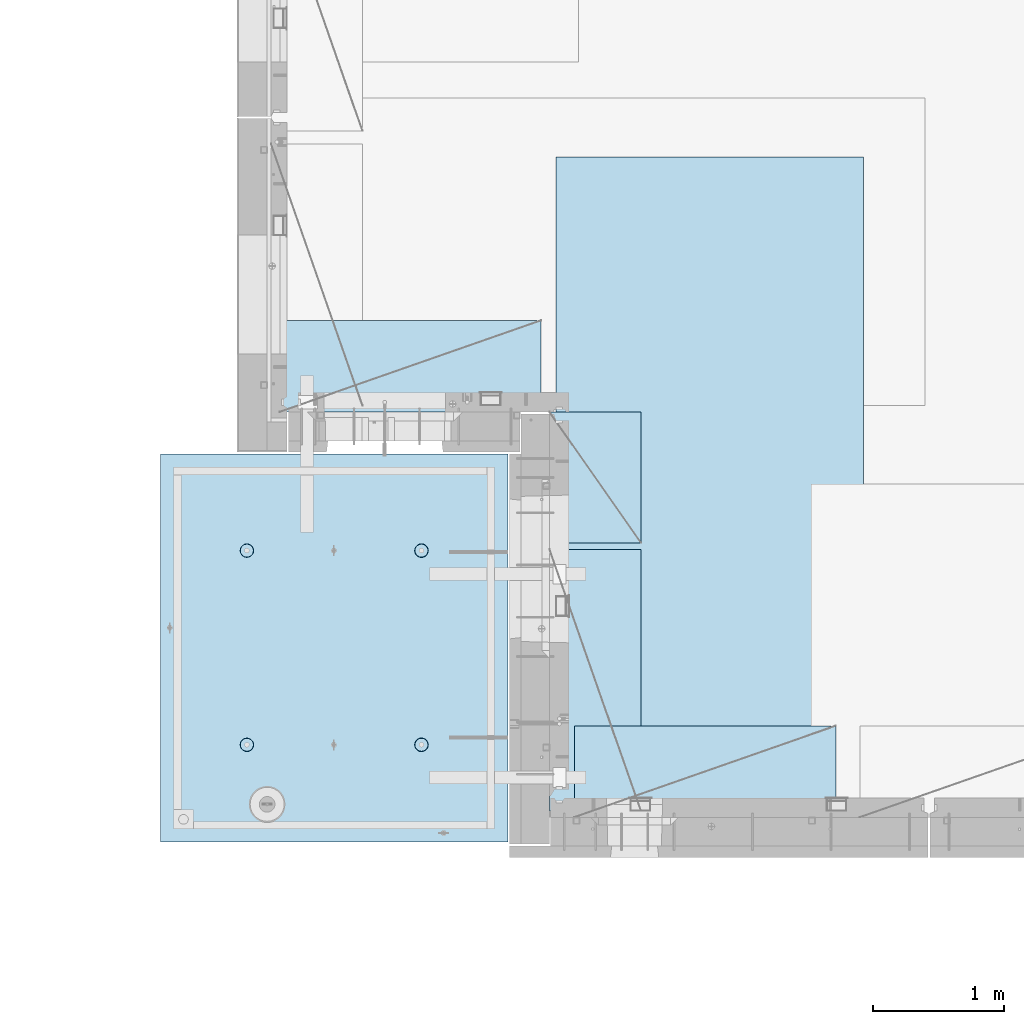
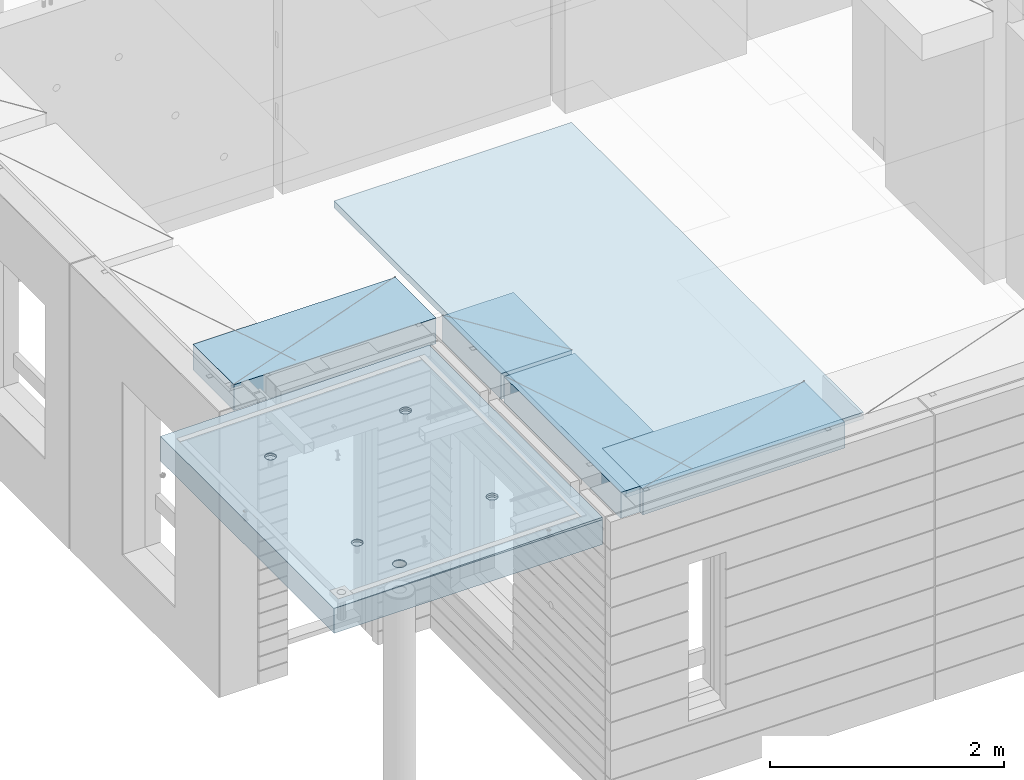
# One storey, part 193 of 341: 5 plates, 2 slabs, 6 elements without a shape of their own.
"""IFC2X3 building model written with IfcOpenShell, lengths in millimetres."""

from ifc_helpers import new_model, si_unit, frame, origin_with_axes, place, context, subcontext, project, spatial, faceted_brep, material, type_object, element, aggregate, save


model = new_model("IFC2X3")

# Units and contexts
model_context = context("Model", 3, precision=1e-05, world=origin_with_axes())
body_context = subcontext(model_context, "Body", "Model", "MODEL_VIEW")
ifc_project = project(units=[si_unit("LENGTHUNIT", "METRE", prefix="MILLI"), si_unit("AREAUNIT", "SQUARE_METRE"), si_unit("VOLUMEUNIT", "CUBIC_METRE"), si_unit("MASSUNIT", "GRAM", prefix="KILO"), si_unit("TIMEUNIT", "SECOND"), si_unit("PLANEANGLEUNIT", "RADIAN"), si_unit("SOLIDANGLEUNIT", "STERADIAN"), si_unit("THERMODYNAMICTEMPERATUREUNIT", "DEGREE_CELSIUS"), si_unit("LUMINOUSINTENSITYUNIT", "LUMEN")], contexts=[model_context])

# Site, building, storey
site_placement = place(None, origin_with_axes())
site = spatial("IfcSite", under=ifc_project, at=site_placement, CompositionType="ELEMENT")
building_placement = place(site_placement, origin_with_axes())
building = spatial("IfcBuilding", under=site, at=building_placement, CompositionType="ELEMENT")
storey_placement = place(building_placement, origin_with_axes())
storey = spatial("IfcBuildingStorey", under=building, at=storey_placement, Name="5", CompositionType="ELEMENT", Elevation=0.0)

# Assembly, slabs
assembly_1_placement = place(storey_placement, origin_with_axes())
assembly_1 = element("IfcElementAssembly", 1, at=assembly_1_placement, inside=storey, AssemblyPlace="NOTDEFINED", PredefinedType="REINFORCEMENT_UNIT")
ifc_material_1 = material(Name="CONCRETE/C35/45")
slab_type_1 = type_object("IfcSlabType", PredefinedType="NOTDEFINED")
slab_1_placement = place(assembly_1_placement, frame((9690.00344264774, 7659.99985681325, 96717.5), z_axis=(-1.0, 3.00000001838171e-08, 0.0), x_axis=(0.0, 1.0, 0.0)))
slab_1 = element("IfcSlab", 2, at=slab_1_placement, type_object=slab_type_1, material=ifc_material_1, PredefinedType="FLOOR", context=body_context, shape_type="Brep", body=[
    faceted_brep([(2970.0, 12.5, 2076.56396484375), (2970.0, 12.5, 2655.10375976563), (2970.0, 7.05330645262438, 2076.56396484375), (2970.0, 12.5, 0.0), (2969.99999999997, -12.5000027287315, -0.000215120240682154), (7.41420080885291e-08, 12.4999999999927, 0.0), (-7.41420080885291e-08, -12.5, -3.63797880709171e-12), (0.0, 12.5, 2655.00366210938), (2246.17288192116, -6.7539579669974, 610.235903379627), (2245.81872714612, 12.5, 611.325879700402), (2230.00000005311, 12.5, 608.820439463128), (2230.00000005311, -6.77809034052189, 607.672934085716), (2260.76019932669, -6.68392947182292, 617.673133503364), (2260.0890070157, 12.5, 618.596950465364), (2272.332530811, -6.57487936261168, 629.254531739907), (2271.41396524135, 12.5, 629.921908691014), (2279.75709784774, -6.43750647555862, 643.843854552742), (2278.68503600632, 12.5, 644.192188560603), (2282.30864751904, -6.2852774275234, 660.010915653605), (2281.19047624359, 12.5, 660.010915653605), (2279.73986529519, -6.13310092446045, 676.172377558725), (2278.68503600632, 12.5, 675.829642746608), (2272.30464795307, -5.995865551522, 690.747041485218), (2271.41396524135, 12.5, 690.099922616197), (2260.73231646608, -5.88698525390646, 702.310320338618), (2260.0890070157, 12.5, 701.424880841847), (2246.15564936427, -5.81709377811057, 709.732891570933), (2245.81872714612, 12.5, 708.695951606809), (2230.00000005311, -5.7930130083696, 712.290261666009), (2230.00000005311, 12.5, 711.201391844083), (2213.8443507625, -5.8170926610037, 709.732891507694), (2214.18127296011, 12.5, 708.695951606811), (2199.2676837145, -5.88698312871566, 702.310320236276), (2199.91099309052, 12.5, 701.424880841847), (2187.69535229405, -5.99586262571393, 690.747041382852), (2188.58603486487, 12.5, 690.099922616197), (2180.26013500581, -6.13309748387837, 676.172377495441), (2181.31496409991, 12.5, 675.829642746608), (2177.6913528026, -6.28527380865125, 660.010915653605), (2178.80952386264, 12.5, 660.010915653605), (2180.24290245339, -6.43750303260458, 643.843854616072), (2181.31496409991, 12.5, 644.192188560603), (2187.66746943631, -6.57487643294735, 629.254531842409), (2188.58603486487, 12.5, 629.921908691014), (2199.23980085403, -6.68392734277586, 617.673133605889), (2199.91099309052, 12.5, 618.596950465364), (2213.82711820565, -6.75395684751857, 610.235903443003), (2214.18127296011, 12.5, 611.325879700402), (761.172882674973, -6.75400078258826, 610.225900828256), (760.818727112381, 12.5, 611.315879572843), (745.000000019378, 12.5, 608.81043933557), (745.000000019378, -6.77813315729145, 607.662931409541), (775.760200790834, -6.68397228400863, 617.663131314152), (775.089006981969, 12.5, 618.586950337805), (787.33253283866, -6.57492216948594, 629.244530114656), (786.413965207619, 12.5, 629.911908563456), (794.757100236948, -6.437549275739, 643.833853637923), (793.685035972581, 12.5, 644.182188433044), (797.308650032492, -6.28532022031141, 660.000915526047), (796.190476209855, 12.5, 660.000915526047), (794.739867683551, -6.13314370981243, 676.162378218156), (793.685035972581, 12.5, 675.81964261905), (787.304649979378, -5.9959083302092, 690.737042854367), (786.413965207619, 12.5, 690.089922488638), (775.732317928869, -5.88702802728221, 702.300322270843), (775.089006981969, 12.5, 701.414880714288), (761.155650117242, -5.81713654809573, 709.722893864604), (760.818727112381, 12.5, 708.68595147925), (745.000000019378, -5.79305577717605, 712.280264084213), (745.000000019378, 12.5, 711.191391716524), (728.844349942063, -5.8171354309743, 709.722893801363), (729.181272926375, 12.5, 708.68595147925), (714.267682184241, -5.88702590207686, 702.300322168503), (714.910993056787, 12.5, 701.414880714288), (702.695350200273, -5.99590540440113, 690.737042752), (703.586034831136, 12.5, 690.089922488638), (695.260132549976, -6.1331402692449, 676.16237815487), (696.314964066174, 12.5, 675.81964261905), (692.691350221674, -6.28531660142471, 660.000915526047), (693.809523828902, 12.5, 660.000915526047), (695.242899996714, -6.43754583279951, 643.833853701251), (696.314964066174, 12.5, 644.182188433044), (702.667467341174, -6.57491923982161, 629.244530217156), (703.586034831136, 12.5, 629.911908563456), (714.239799322411, -6.68397015496157, 617.663131416677), (714.910993056787, 12.5, 618.586950337805), (728.827117384375, -6.75399966310943, 610.225900891632), (729.181272926375, 12.5, 611.315879572843), (760.941541335169, 5.82308796475991, 1945.93972725137), (760.818727091786, 12.5, 1946.31771062636), (744.999999998783, 12.5, 1943.81227038909), (744.999999998783, 5.79930078610778, 1943.4134192454), (775.320198478928, 5.89211475661432, 1953.2705735664), (775.089006961374, 12.5, 1953.58878139132), (786.72699673669, 5.99960498859582, 1964.68630888353), (786.413965187025, 12.5, 1964.91373961697), (794.045361100365, 6.13501286304381, 1979.06694274881), (793.685035951987, 12.5, 1979.18401948656), (796.560412832556, 6.28506439260673, 1995.00274657956), (796.190476189258, 12.5, 1995.00274657956), (794.028375046106, 6.43506412883289, 2010.93303130673), (793.685035951987, 12.5, 2010.82147367257), (786.699512721421, 6.57033645619231, 2025.29921596966), (786.413965187025, 12.5, 2025.09175354215), (775.292714461017, 6.67765930559835, 2036.69709108738), (775.089006961374, 12.5, 2036.41671176781), (760.924555276639, 6.74655103802797, 2044.01348819506), (760.818727091786, 12.5, 2043.68778253277), (744.999999998783, 6.7702873510425, 2046.53427709438), (744.999999998783, 12.5, 2046.19322277004), (729.075444741182, 6.7465521391714, 2044.01348813272), (729.18127290578, 12.5, 2043.68778253277), (714.70728560984, 6.67766140039021, 2036.6970909865), (714.910993036192, 12.5, 2036.41671176781), (703.300487415023, 6.57033934014908, 2025.29921586876), (703.586034810542, 12.5, 2025.09175354216), (695.971625143447, 6.43506752018584, 2010.93303124435), (696.314964045579, 12.5, 2010.82147367257), (693.439587377337, 6.28506795971771, 1995.00274657956), (693.809523808306, 12.5, 1995.00274657956), (695.954639089321, 6.13501625673962, 1979.06694281123), (696.314964045579, 12.5, 1979.18401948656), (703.273003399938, 5.99960787635064, 1964.68630898457), (703.586034810542, 12.5, 1964.91373961697), (714.679801592063, 5.89211685521877, 1953.27057366746), (714.910993036192, 12.5, 1953.58878139132), (729.058458682694, 5.82308906823164, 1945.93972731384), (729.18127290578, 12.5, 1946.31771062636), (2178.80952377932, 12.5, 1995.00274667064), (2178.43958429075, 6.28501659208268, 1995.00274667064), (2180.95463615188, 6.13496488021337, 1979.06694195729), (2181.31496401659, 12.5, 1979.18401957764), (2181.31496401659, 12.5, 2010.82147376364), (2180.97162220701, 6.43501616145659, 2010.93303228012), (2188.58603478155, 12.5, 2025.09175363323), (2188.3004849132, 6.57028798943793, 2025.29921775646), (2199.9109930072, 12.5, 2036.41671185888), (2199.70728378446, 6.6776100560528, 2036.6970935501), (2214.18127287679, 12.5, 2043.68778262385), (2214.07544376785, 6.74650079890853, 2044.0134911302), (2229.9999999698, 12.5, 2046.19322286112), (2229.9999999698, 6.77023601217661, 2046.53428024135), (2245.8187270628, 12.5, 2043.68778262385), (2245.924556192, 6.7464996977651, 2044.01349119253), (2260.08900693239, 12.5, 2036.41671185888), (2260.29271622843, 6.67760796126095, 2036.69709365098), (2271.41396515804, 12.5, 2025.09175363323), (2271.69951516527, 6.57028510548116, 2025.29921785736), (2278.685035923, 12.5, 2010.82147376364), (2279.02837792456, 6.43501277010364, 2010.9330323425), (2281.19047616027, 12.5, 1995.00274667064), (2281.56041586117, 6.2850130249717, 1995.00274667064), (2278.685035923, 12.5, 1979.18401957764), (2279.04536397983, 6.13496148651757, 1979.06694189487), (2271.41396515804, 12.5, 1964.91373970805), (2271.72699918216, 5.99955360403692, 1964.68630717681), (2260.08900693239, 12.5, 1953.5887814824), (2260.32020024797, 5.89206336568168, 1953.2705711827), (2245.8187270628, 12.5, 1946.31771071744), (2245.94154225154, 5.82303656973818, 1945.93972443295), (254.731823253564, 4.36849820162752, 1791.45731182264), (241.457918728614, 4.49348581883532, 1804.73121634759), (232.935547413403, 4.65097912067722, 1821.45731182264), (229.998938391112, 4.82556156541978, 1839.99833148514), (232.935547413403, 5.00014380698849, 1858.53935114764), (241.457918728614, 5.15763651921588, 1875.26544662269), (254.731823253564, 5.28262321809598, 1888.53935114764), (271.457918728614, 5.36286933471274, 1897.06172246285), (289.998938391112, 5.3905198200664, 1899.99833148514), (308.539958053609, 5.36286805199052, 1897.06172246285), (325.26605352866, 5.28262077822001, 1888.53935114764), (338.539958053609, 5.15763316099765, 1875.26544662269), (347.06232936882, 5.0001398591703, 1858.53935114764), (349.998938391112, 4.82555741442775, 1839.99833148514), (347.06232936882, 4.65097517284448, 1821.45731182264), (338.539958053609, 4.49348246061709, 1804.73121634759), (325.26605352866, 4.36849576173699, 1791.45731182264), (308.539958053609, 4.28824964510568, 1782.93494050743), (289.998938391112, 4.26059915976657, 1779.99833148514), (271.457918728614, 4.28825092784246, 1782.93494050743), (2199.67979976505, 5.89206546428613, 1953.27057128376), (2188.27300089649, 5.99955649179174, 1964.68630727784), (2229.9999999698, 5.79924938967451, 1943.41341627717), (2214.05845770835, 5.82303767320991, 1945.93972449542), (2188.58603478155, 12.5, 1964.91373970805), (2199.9109930072, 12.5, 1953.5887814824), (2214.18127287679, 12.5, 1946.31771071744), (2229.9999999698, 12.5, 1943.81227048017), (325.26605352866, 12.5, 1791.45731182264), (338.539958053609, 12.5, 1804.73121634759), (347.06232936882, 12.5, 1821.45731182264), (349.998938391112, 12.5, 1839.99833148514), (347.06232936882, 12.5, 1858.53935114764), (338.539958053609, 12.5, 1875.26544662269), (325.26605352866, 12.5, 1888.53935114764), (308.539958053609, 12.5, 1897.06172246285), (289.998938391112, 12.5, 1899.99833148514), (271.457918728614, 12.5, 1897.06172246285), (254.731823253564, 12.5, 1888.53935114764), (241.457918728614, 12.5, 1875.26544662269), (232.935547413403, 12.5, 1858.53935114764), (229.998938391112, 12.5, 1839.99833148514), (232.935547413403, 12.5, 1821.45731182264), (241.457918728614, 12.5, 1804.73121634759), (254.731823253564, 12.5, 1791.45731182264), (271.457918728614, 12.5, 1782.93494050743), (289.998938391112, 12.5, 1779.99833148514), (308.539958053609, 12.5, 1782.93494050743)], [[[0, 1, 2]], [[3, 0, 2, 4]], [[5, 3, 4, 6]], [[5, 6, 7]], [[8, 9, 10, 11]], [[12, 13, 9, 8]], [[14, 15, 13, 12]], [[16, 17, 15, 14]], [[18, 19, 17, 16]], [[20, 21, 19, 18]], [[21, 20, 22, 23]], [[23, 22, 24, 25]], [[25, 24, 26, 27]], [[27, 26, 28, 29]], [[29, 28, 30, 31]], [[31, 30, 32, 33]], [[33, 32, 34, 35]], [[35, 34, 36, 37]], [[37, 36, 38, 39]], [[40, 41, 39, 38]], [[42, 43, 41, 40]], [[44, 45, 43, 42]], [[46, 47, 45, 44]], [[11, 10, 47, 46]], [[48, 49, 50, 51]], [[52, 53, 49, 48]], [[54, 55, 53, 52]], [[56, 57, 55, 54]], [[58, 59, 57, 56]], [[60, 61, 59, 58]], [[61, 60, 62, 63]], [[63, 62, 64, 65]], [[65, 64, 66, 67]], [[67, 66, 68, 69]], [[69, 68, 70, 71]], [[71, 70, 72, 73]], [[73, 72, 74, 75]], [[75, 74, 76, 77]], [[77, 76, 78, 79]], [[80, 81, 79, 78]], [[82, 83, 81, 80]], [[84, 85, 83, 82]], [[86, 87, 85, 84]], [[51, 50, 87, 86]], [[88, 89, 90, 91]], [[92, 93, 89, 88]], [[94, 95, 93, 92]], [[96, 97, 95, 94]], [[98, 99, 97, 96]], [[100, 101, 99, 98]], [[102, 103, 101, 100]], [[104, 105, 103, 102]], [[105, 104, 106, 107]], [[107, 106, 108, 109]], [[109, 108, 110, 111]], [[111, 110, 112, 113]], [[113, 112, 114, 115]], [[115, 114, 116, 117]], [[117, 116, 118, 119]], [[119, 118, 120, 121]], [[121, 120, 122, 123]], [[124, 125, 123, 122]], [[126, 127, 125, 124]], [[91, 90, 127, 126]], [[128, 129, 130, 131]], [[132, 133, 129, 128]], [[134, 135, 133, 132]], [[136, 137, 135, 134]], [[138, 139, 137, 136]], [[140, 141, 139, 138]], [[142, 143, 141, 140]], [[144, 145, 143, 142]], [[145, 144, 146, 147]], [[147, 146, 148, 149]], [[149, 148, 150, 151]], [[151, 150, 152, 153]], [[153, 152, 154, 155]], [[155, 154, 156, 157]], [[157, 156, 158, 159]], [[4, 2, 1, 7, 6], [160, 161, 162, 163, 164, 165, 166, 167, 168, 169, 170, 171, 172, 173, 174, 175, 176, 177, 178, 179], [180, 181, 130, 129, 133, 135, 137, 139, 141, 143, 145, 147, 149, 151, 153, 155, 157, 159, 182, 183], [124, 122, 120, 118, 116, 114, 112, 110, 108, 106, 104, 102, 100, 98, 96, 94, 92, 88, 91, 126], [84, 82, 80, 78, 76, 74, 72, 70, 68, 66, 64, 62, 60, 58, 56, 54, 52, 48, 51, 86], [44, 42, 40, 38, 36, 34, 32, 30, 28, 26, 24, 22, 20, 18, 16, 14, 12, 8, 11, 46]], [[131, 130, 181, 184]], [[180, 185, 184, 181]], [[183, 186, 185, 180]], [[182, 187, 186, 183]], [[159, 158, 187, 182]], [[0, 3, 5, 7, 1], [188, 189, 190, 191, 192, 193, 194, 195, 196, 197, 198, 199, 200, 201, 202, 203, 204, 205, 206, 207], [156, 154, 152, 150, 148, 146, 144, 142, 140, 138, 136, 134, 132, 128, 131, 184, 185, 186, 187, 158], [93, 95, 97, 99, 101, 103, 105, 107, 109, 111, 113, 115, 117, 119, 121, 123, 125, 127, 90, 89], [53, 55, 57, 59, 61, 63, 65, 67, 69, 71, 73, 75, 77, 79, 81, 83, 85, 87, 50, 49], [13, 15, 17, 19, 21, 23, 25, 27, 29, 31, 33, 35, 37, 39, 41, 43, 45, 47, 10, 9]], [[178, 206, 205, 179]], [[177, 207, 206, 178]], [[176, 188, 207, 177]], [[175, 189, 188, 176]], [[174, 190, 189, 175]], [[173, 191, 190, 174]], [[172, 192, 191, 173]], [[171, 193, 192, 172]], [[170, 194, 193, 171]], [[169, 195, 194, 170]], [[168, 196, 195, 169]], [[167, 197, 196, 168]], [[166, 198, 197, 167]], [[165, 199, 198, 166]], [[164, 200, 199, 165]], [[163, 201, 200, 164]], [[162, 202, 201, 163]], [[161, 203, 202, 162]], [[160, 204, 203, 161]], [[179, 205, 204, 160]]]),
])
slab_type_2 = type_object("IfcSlabType", PredefinedType="NOTDEFINED")
slab_2_placement = place(assembly_1_placement, frame((9690.00344264774, 7659.99985681325, 96575.0), z_axis=(-0.999999999997437, -2.26400000064461e-06, 0.0), x_axis=(-2.2639999995273e-06, 0.999999999997437, 0.0)))
slab_2 = element("IfcSlab", 3, at=slab_2_placement, type_object=slab_type_2, material=ifc_material_1, PredefinedType="FLOOR", context=body_context, shape_type="Brep", body=[
    faceted_brep([(2245.45536387143, -110.0, 1947.44471589559), (2259.39379322965, -110.0, 1954.54665968234), (2270.4554059745, -110.0, 1965.60822114567), (2277.55741437973, -110.0, 1979.54661757913), (2280.00462438004, -110.0, 1994.99746162528), (2277.55748600988, -110.0, 2010.44831701654), (2270.45554222312, -110.0, 2024.38674637476), (2259.39398075979, -110.0, 2035.44835911961), (2245.45558432633, -110.0, 2042.55036752485), (2230.00474028018, -110.0, 2044.99757752515), (2214.55388488892, -110.0, 2042.55043915498), (2200.6154555307, -110.0, 2035.44849536823), (2189.55384278585, -110.0, 2024.3869339049), (2182.45183438062, -110.0, 2010.44853747144), (2180.00462438031, -110.0, 1994.99769342529), (2182.45176275048, -110.0, 1979.54683803403), (2189.55370653723, -110.0, 1965.60840867581), (2200.61526800056, -110.0, 1954.54679593096), (2214.55366443402, -110.0, 1947.44478752572), (2230.00450848018, -110.0, 1944.99757752542), (2260.09353534512, -130.0, 1953.58354259084), (2245.82323862122, -130.0, 1946.3125049044), (2271.41851982199, -130.0, 1964.9084745652), (2278.68962366544, -130.0, 1979.17873758041), (2281.19510057052, -130.0, 1994.99745886576), (2278.68969700106, -130.0, 2010.81619176633), (2271.41865931462, -130.0, 2025.08648849022), (2260.09372734026, -130.0, 2036.4114729671), (2245.82346432505, -130.0, 2043.68257681055), (2230.0047430397, -130.0, 2046.18805371562), (2214.18601013913, -130.0, 2043.68265014617), (2199.91571341524, -130.0, 2036.41161245973), (2188.59072893836, -130.0, 2025.08668048537), (2181.31962509491, -130.0, 2010.81641747016), (2178.81414818984, -130.0, 1994.99769618481), (2181.31955175929, -130.0, 1979.17896328424), (2188.59058944573, -130.0, 1964.90866656035), (2199.91552142009, -130.0, 1953.58368208347), (2214.1857844353, -130.0, 1946.31257824002), (2230.00450572065, -130.0, 1943.80710133495), (760.455363904408, -110.0, 1947.44815803451), (774.393793262629, -110.0, 1954.55010182126), (785.455406007481, -110.0, 1965.61166328459), (792.557414412711, -110.0, 1979.55005971805), (795.004624413019, -110.0, 1995.00090376421), (792.557486042851, -110.0, 2010.45175915546), (785.455542256102, -110.0, 2024.39018851368), (774.393980792767, -110.0, 2035.45180125853), (760.455584359308, -110.0, 2042.55380966377), (745.004740313152, -110.0, 2045.00101966407), (729.553884921896, -110.0, 2042.55388129391), (715.615455563677, -110.0, 2035.45193750716), (704.553842818825, -110.0, 2024.39037604382), (697.451834413594, -110.0, 2010.45197961036), (695.004624413286, -110.0, 1995.00113556421), (697.451762783454, -110.0, 1979.55028017295), (704.553706570203, -110.0, 1965.61185081473), (715.615268033538, -110.0, 1954.55023806988), (729.553664466996, -110.0, 1947.44822966465), (745.004508513151, -110.0, 1945.00101966434), (760.823238654199, -130.0, 1946.31594704332), (745.004505753628, -130.0, 1943.81054347387), (775.093535378091, -130.0, 1953.58698472976), (786.418519854964, -130.0, 1964.91191670413), (793.689623698416, -130.0, 1979.18217971933), (796.195100603492, -130.0, 1995.00090100468), (793.689697034035, -130.0, 2010.81963390525), (786.418659347601, -130.0, 2025.08993062915), (775.093727373234, -130.0, 2036.41491510602), (760.823464358025, -130.0, 2043.68601894947), (745.004743072675, -130.0, 2046.19149585455), (729.186010172105, -130.0, 2043.68609228509), (714.915713448214, -130.0, 2036.41505459866), (703.590728971341, -130.0, 2025.09012262429), (696.319625127888, -130.0, 2010.81985960908), (693.814148222813, -130.0, 1995.00113832373), (696.319551792269, -130.0, 1979.18240542316), (703.590589478705, -130.0, 1964.91210869927), (714.915521453071, -130.0, 1953.5871242224), (729.185784468278, -130.0, 1946.31602037894), (2970.0, -130.0, 1.11504050437361e-09), (0.0, -130.0, -3.63797880709171e-12), (0.0, 130.0, -1.81898940354586e-12), (2970.0, 130.0, 1.11504050437361e-09), (2970.0048828125, -130.0, 2076.55712890625), (2970.0048828125, 130.0, 2076.55712890625), (2970.00610351563, -130.0, 2655.0966796875), (2970.00610351563, 130.0, 2655.0966796875), (0.00277573079893045, -130.0, 2655.00366210937), (0.00277573079893045, 130.0, 2655.00366210937), (325.270206125839, 130.0, 1791.45655785112), (338.544141419662, 130.0, 1804.73043160713), (347.066551505941, 130.0, 1821.45650732727), (350.003203506308, 130.0, 1839.99752018266), (347.066637462108, 130.0, 1858.53854665217), (338.544304918008, 130.0, 1875.26466188203), (325.270431162006, 130.0, 1888.53859717586), (308.544355441856, 130.0, 1897.06100726213), (290.003342586469, 130.0, 1899.9976592625), (271.462316116962, 130.0, 1897.0610932183), (254.7362008871, 130.0, 1888.5387606742), (241.462265593274, 130.0, 1875.2648869182), (232.939855506997, 130.0, 1858.53881119805), (230.00320350663, 130.0, 1839.99779834266), (232.93976955083, 130.0, 1821.45677187316), (241.462102094929, 130.0, 1804.73065664329), (254.735975850932, 130.0, 1791.45672134947), (271.462051571081, 130.0, 1782.93431126319), (290.003064426469, 130.0, 1779.99765926282), (308.544090895975, 130.0, 1782.93422530702), (308.544090895975, -130.0, 1782.93422530702), (290.003064426469, -130.0, 1779.99765926282), (325.270206125839, -130.0, 1791.45655785112), (338.544141419662, -130.0, 1804.73043160713), (347.066551505941, -130.0, 1821.45650732727), (350.003203506308, -130.0, 1839.99752018266), (347.066637462108, -130.0, 1858.53854665217), (338.544304918008, -130.0, 1875.26466188203), (325.270431162006, -130.0, 1888.53859717586), (308.544355441856, -130.0, 1897.06100726213), (290.003342586469, -130.0, 1899.9976592625), (271.462316116962, -130.0, 1897.0610932183), (254.7362008871, -130.0, 1888.5387606742), (241.462265593274, -130.0, 1875.2648869182), (232.939855506997, -130.0, 1858.53881119805), (230.00320350663, -130.0, 1839.99779834266), (232.93976955083, -130.0, 1821.45677187316), (241.462102094929, -130.0, 1804.73065664329), (254.735975850932, -130.0, 1791.45672134947), (271.462051571081, -130.0, 1782.93431126319), (760.452269390758, -110.0, 612.446326984578), (774.390698748979, -110.0, 619.548270771327), (785.452311493831, -110.0, 630.609832234661), (792.554319899062, -110.0, 644.54822866812), (795.001529899369, -110.0, 659.999072714278), (792.554391529202, -110.0, 675.449928105532), (785.452447742453, -110.0, 689.388357463751), (774.390886279118, -110.0, 700.449970208605), (760.452489845658, -110.0, 707.551978613836), (745.001645799503, -110.0, 709.999188614142), (729.550790408246, -110.0, 707.552050243974), (715.612361050027, -110.0, 700.450106457225), (704.550748305175, -110.0, 689.388544993892), (697.448739899944, -110.0, 675.450148560432), (695.001529899637, -110.0, 659.999304514276), (697.448668269804, -110.0, 644.54844912302), (704.550612056553, -110.0, 630.610019764801), (715.612173519889, -110.0, 619.548407019947), (729.550569953346, -110.0, 612.446398614717), (745.001413999502, -110.0, 609.999188614411), (760.820144140549, -130.0, 611.314115993395), (745.001411239979, -130.0, 608.808712423936), (775.090440864442, -130.0, 618.585153679829), (786.415425341314, -130.0, 629.910085654195), (793.686529184766, -130.0, 644.180348669403), (796.192006089843, -130.0, 659.999069954752), (793.686602520385, -130.0, 675.817802855323), (786.415564833951, -130.0, 690.088099579216), (775.090632859585, -130.0, 701.41308405609), (760.820369844376, -130.0, 708.68418789954), (745.001648559026, -130.0, 711.189664804615), (729.182915658455, -130.0, 708.684261235159), (714.912618934564, -130.0, 701.413223548725), (703.587634457692, -130.0, 690.088291574357), (696.316530614238, -130.0, 675.81802855915), (693.811053709163, -130.0, 659.999307273802), (696.316457278619, -130.0, 644.180574373229), (703.587494965055, -130.0, 629.910277649336), (714.912426939421, -130.0, 618.585293172464), (729.182689954629, -130.0, 611.314189329014), (2245.45226944368, -110.0, 612.452884882137), (2259.3906988019, -110.0, 619.554828668886), (2270.45231154675, -110.0, 630.61639013222), (2277.55431995199, -110.0, 644.554786565679), (2280.00152995229, -110.0, 660.005630611837), (2277.55439158212, -110.0, 675.456486003091), (2270.45244779537, -110.0, 689.39491536131), (2259.39088633204, -110.0, 700.456528106164), (2245.45248989858, -110.0, 707.558536511395), (2230.00164585242, -110.0, 710.005746511701), (2214.55079046117, -110.0, 707.558608141533), (2200.61236110295, -110.0, 700.456664354784), (2189.5507483581, -110.0, 689.395102891451), (2182.44873995286, -110.0, 675.456706457991), (2180.00152995256, -110.0, 660.005862411836), (2182.44866832273, -110.0, 644.555007020579), (2189.55061210948, -110.0, 630.61657766236), (2200.61217357281, -110.0, 619.554964917506), (2214.55057000627, -110.0, 612.452956512276), (2230.00141405243, -110.0, 610.00574651197), (2245.82014419347, -130.0, 611.320673890954), (2230.0014112929, -130.0, 608.815270321495), (2260.09044091736, -130.0, 618.591711577388), (2271.41542539424, -130.0, 629.916643551753), (2278.68652923769, -130.0, 644.186906566962), (2281.19200614276, -130.0, 660.005627852312), (2278.68660257331, -130.0, 675.824360752882), (2271.41556488687, -130.0, 690.094657476773), (2260.09063291251, -130.0, 701.419641953647), (2245.8203698973, -130.0, 708.690745797099), (2230.00164861195, -130.0, 711.196222702174), (2214.18291571138, -130.0, 708.690819132718), (2199.91261898749, -130.0, 701.419781446282), (2188.58763451061, -130.0, 690.094849471916), (2181.31653066716, -130.0, 675.824586456709), (2178.81105376209, -130.0, 660.005865171361), (2181.31645733154, -130.0, 644.187132270788), (2188.58749501798, -130.0, 629.916835546896), (2199.91242699234, -130.0, 618.591851070023), (2214.18269000755, -130.0, 611.320747226573)], [[[0, 1, 2, 3, 4, 5, 6, 7, 8, 9, 10, 11, 12, 13, 14, 15, 16, 17, 18, 19]], [[20, 1, 0, 21]], [[22, 2, 1, 20]], [[23, 3, 2, 22]], [[24, 4, 3, 23]], [[25, 5, 4, 24]], [[26, 6, 5, 25]], [[27, 7, 6, 26]], [[28, 8, 7, 27]], [[29, 9, 8, 28]], [[30, 10, 9, 29]], [[31, 11, 10, 30]], [[32, 12, 11, 31]], [[33, 13, 12, 32]], [[34, 14, 13, 33]], [[35, 15, 14, 34]], [[36, 16, 15, 35]], [[37, 17, 16, 36]], [[38, 18, 17, 37]], [[39, 19, 18, 38]], [[21, 0, 19, 39]], [[40, 41, 42, 43, 44, 45, 46, 47, 48, 49, 50, 51, 52, 53, 54, 55, 56, 57, 58, 59]], [[60, 40, 59, 61]], [[62, 41, 40, 60]], [[63, 42, 41, 62]], [[64, 43, 42, 63]], [[65, 44, 43, 64]], [[66, 45, 44, 65]], [[67, 46, 45, 66]], [[68, 47, 46, 67]], [[69, 48, 47, 68]], [[70, 49, 48, 69]], [[71, 50, 49, 70]], [[72, 51, 50, 71]], [[73, 52, 51, 72]], [[74, 53, 52, 73]], [[75, 54, 53, 74]], [[76, 55, 54, 75]], [[77, 56, 55, 76]], [[78, 57, 56, 77]], [[79, 58, 57, 78]], [[61, 59, 58, 79]], [[80, 81, 82, 83]], [[84, 80, 83, 85]], [[86, 84, 85, 87]], [[88, 86, 87, 89]], [[81, 88, 89, 82]], [[87, 85, 83, 82, 89], [90, 91, 92, 93, 94, 95, 96, 97, 98, 99, 100, 101, 102, 103, 104, 105, 106, 107, 108, 109]], [[110, 109, 108, 111]], [[112, 90, 109, 110]], [[113, 91, 90, 112]], [[114, 92, 91, 113]], [[115, 93, 92, 114]], [[116, 94, 93, 115]], [[117, 95, 94, 116]], [[118, 96, 95, 117]], [[119, 97, 96, 118]], [[120, 98, 97, 119]], [[121, 99, 98, 120]], [[122, 100, 99, 121]], [[123, 101, 100, 122]], [[124, 102, 101, 123]], [[125, 103, 102, 124]], [[126, 104, 103, 125]], [[127, 105, 104, 126]], [[128, 106, 105, 127]], [[129, 107, 106, 128]], [[111, 108, 107, 129]], [[130, 131, 132, 133, 134, 135, 136, 137, 138, 139, 140, 141, 142, 143, 144, 145, 146, 147, 148, 149]], [[150, 130, 149, 151]], [[152, 131, 130, 150]], [[153, 132, 131, 152]], [[154, 133, 132, 153]], [[155, 134, 133, 154]], [[156, 135, 134, 155]], [[157, 136, 135, 156]], [[158, 137, 136, 157]], [[159, 138, 137, 158]], [[160, 139, 138, 159]], [[161, 140, 139, 160]], [[162, 141, 140, 161]], [[163, 142, 141, 162]], [[164, 143, 142, 163]], [[165, 144, 143, 164]], [[166, 145, 144, 165]], [[167, 146, 145, 166]], [[168, 147, 146, 167]], [[169, 148, 147, 168]], [[151, 149, 148, 169]], [[170, 171, 172, 173, 174, 175, 176, 177, 178, 179, 180, 181, 182, 183, 184, 185, 186, 187, 188, 189]], [[190, 170, 189, 191]], [[192, 171, 170, 190]], [[193, 172, 171, 192]], [[194, 173, 172, 193]], [[195, 174, 173, 194]], [[196, 175, 174, 195]], [[197, 176, 175, 196]], [[198, 177, 176, 197]], [[199, 178, 177, 198]], [[200, 179, 178, 199]], [[201, 180, 179, 200]], [[202, 181, 180, 201]], [[203, 182, 181, 202]], [[204, 183, 182, 203]], [[205, 184, 183, 204]], [[206, 185, 184, 205]], [[207, 186, 185, 206]], [[208, 187, 186, 207]], [[209, 188, 187, 208]], [[191, 189, 188, 209]], [[80, 84, 86, 88, 81], [37, 36, 35, 34, 33, 32, 31, 30, 29, 28, 27, 26, 25, 24, 23, 22, 20, 21, 39, 38], [208, 207, 206, 205, 204, 203, 202, 201, 200, 199, 198, 197, 196, 195, 194, 193, 192, 190, 191, 209], [168, 167, 166, 165, 164, 163, 162, 161, 160, 159, 158, 157, 156, 155, 154, 153, 152, 150, 151, 169], [128, 127, 126, 125, 124, 123, 122, 121, 120, 119, 118, 117, 116, 115, 114, 113, 112, 110, 111, 129], [78, 77, 76, 75, 74, 73, 72, 71, 70, 69, 68, 67, 66, 65, 64, 63, 62, 60, 61, 79]]]),
])
aggregate(assembly_1, [slab_1, slab_2])

# Assembly, plate
assembly_2_placement = place(storey_placement, origin_with_axes())
assembly_2 = element("IfcElementAssembly", 4, at=assembly_2_placement, inside=storey, Name="Steel Assembly", AssemblyPlace="NOTDEFINED", PredefinedType="NOTDEFINED")
ifc_material_2 = material()
plate_type_1 = type_object("IfcPlateType", PredefinedType="NOTDEFINED")
plate_1_placement = place(assembly_2_placement, frame((10060.0, 7900.0, 96695.1), z_axis=(0.0, 1.0, 0.0), x_axis=(1.0, 0.0, 0.0)))
plate_1 = element("IfcPlate", 5, at=plate_1_placement, type_object=plate_type_1, material=ifc_material_2, context=body_context, shape_type="Brep", body=[
    faceted_brep([(0.0, -35.0, 0.0), (0.0, -35.0, 5000.0), (0.0, 35.0, 5000.0), (0.0, 35.0, 0.0), (2349.99951171875, -35.0, 5000.0), (2349.99951171875, 35.0, 5000.0), (2350.0, -35.0, 0.0), (2350.0, 35.0, 0.0)], [[[0, 1, 2, 3]], [[1, 4, 5, 2]], [[4, 6, 7, 5]], [[6, 0, 3, 7]], [[5, 7, 3, 2]], [[6, 4, 1, 0]]]),
])
aggregate(assembly_2, [plate_1])

assembly_3_placement = place(storey_placement, origin_with_axes())
assembly_3 = element("IfcElementAssembly", 6, at=assembly_3_placement, inside=storey, Name="Steel Assembly", AssemblyPlace="NOTDEFINED", PredefinedType="NOTDEFINED")
plate_type_2 = type_object("IfcPlateType", PredefinedType="NOTDEFINED")
plate_2_placement = place(assembly_3_placement, frame((7945.00085423865, 10950.0001036336, 96595.3), z_axis=(0.0, 1.0, 0.0), x_axis=(1.0, 0.0, 0.0)))
plate_2 = element("IfcPlate", 7, at=plate_2_placement, type_object=plate_type_2, material=ifc_material_2, Name="RE1", context=body_context, shape_type="Brep", body=[
    faceted_brep([(1.81898940354586e-12, -135.0, 1.81898940354586e-12), (0.0, -135.0, 699.999999999996), (0.0, 135.0, 699.999999999996), (1.81898940354586e-12, 135.0, 1.81898940354586e-12), (1999.99951171875, -135.0, 699.999999999993), (1999.99951171875, 135.0, 699.999999999993), (2000.0, -135.0, -3.63797880709171e-12), (2000.0, 135.0, -3.63797880709171e-12)], [[[0, 1, 2, 3]], [[1, 4, 5, 2]], [[4, 6, 7, 5]], [[6, 0, 3, 7]], [[5, 7, 3, 2]], [[6, 4, 1, 0]]]),
])
aggregate(assembly_3, [plate_2])

assembly_4_placement = place(storey_placement, origin_with_axes())
assembly_4 = element("IfcElementAssembly", 8, at=assembly_4_placement, inside=storey, Name="Steel Assembly", AssemblyPlace="NOTDEFINED", PredefinedType="NOTDEFINED")
plate_3_placement = place(assembly_4_placement, frame((10009.9998779297, 9900.0, 96595.3), z_axis=(1.0, 0.0, 0.0), x_axis=(0.0, -1.0, 0.0)))
plate_3 = element("IfcPlate", 9, at=plate_3_placement, type_object=plate_type_2, material=ifc_material_2, Name="RE1", context=body_context, shape_type="Brep", body=[
    faceted_brep([(1.81898940354586e-12, -135.0, 1.81898940354586e-12), (0.0, -135.0, 699.999999999996), (0.0, 135.0, 699.999999999996), (1.81898940354586e-12, 135.0, 1.81898940354586e-12), (1999.99951171875, -135.0, 699.999999999993), (1999.99951171875, 135.0, 699.999999999993), (2000.0, -135.0, -3.63797880709171e-12), (2000.0, 135.0, -3.63797880709171e-12)], [[[0, 1, 2, 3]], [[1, 4, 5, 2]], [[4, 6, 7, 5]], [[6, 0, 3, 7]], [[5, 7, 3, 2]], [[6, 4, 1, 0]]]),
])
aggregate(assembly_4, [plate_3])

assembly_5_placement = place(storey_placement, origin_with_axes())
assembly_5 = element("IfcElementAssembly", 10, at=assembly_5_placement, inside=storey, Name="Steel Assembly", AssemblyPlace="NOTDEFINED", PredefinedType="NOTDEFINED")
plate_4_placement = place(assembly_5_placement, frame((10009.9999999293, 10950.0, 96595.3), z_axis=(1.0, 0.0, 0.0), x_axis=(0.0, -1.0, 0.0)))
plate_4 = element("IfcPlate", 11, at=plate_4_placement, type_object=plate_type_2, material=ifc_material_2, Name="RE1_1/2", context=body_context, shape_type="Brep", body=[
    faceted_brep([(1.81898940354586e-12, -135.0, 1.81898940354586e-12), (0.0, -135.0, 699.999999999996), (0.0, 135.0, 699.999999999996), (1.81898940354586e-12, 135.0, 1.81898940354586e-12), (999.99951171875, -135.0, 700.0), (999.99951171875, 135.0, 700.0), (1000.0, -135.0, 0.0), (1000.0, 135.0, 0.0)], [[[0, 1, 2, 3]], [[1, 4, 5, 2]], [[4, 6, 7, 5]], [[6, 0, 3, 7]], [[5, 7, 3, 2]], [[6, 4, 1, 0]]]),
])
aggregate(assembly_5, [plate_4])

assembly_6_placement = place(storey_placement, origin_with_axes())
assembly_6 = element("IfcElementAssembly", 12, at=assembly_6_placement, inside=storey, Name="Steel Assembly", AssemblyPlace="NOTDEFINED", PredefinedType="NOTDEFINED")
plate_5_placement = place(assembly_6_placement, frame((10200.0008542386, 7850.00010363356, 96595.3), z_axis=(0.0, 1.0, 0.0), x_axis=(1.0, 0.0, 0.0)))
plate_5 = element("IfcPlate", 13, at=plate_5_placement, type_object=plate_type_2, material=ifc_material_2, Name="RE1", context=body_context, shape_type="Brep", body=[
    faceted_brep([(1.81898940354586e-12, -135.0, 1.81898940354586e-12), (0.0, -135.0, 699.999999999996), (0.0, 135.0, 699.999999999996), (1.81898940354586e-12, 135.0, 1.81898940354586e-12), (1999.99951171875, -135.0, 699.999999999993), (1999.99951171875, 135.0, 699.999999999993), (2000.0, -135.0, -3.63797880709171e-12), (2000.0, 135.0, -3.63797880709171e-12)], [[[0, 1, 2, 3]], [[1, 4, 5, 2]], [[4, 6, 7, 5]], [[6, 0, 3, 7]], [[5, 7, 3, 2]], [[6, 4, 1, 0]]]),
])
aggregate(assembly_6, [plate_5])

save(model, "model.ifc")
